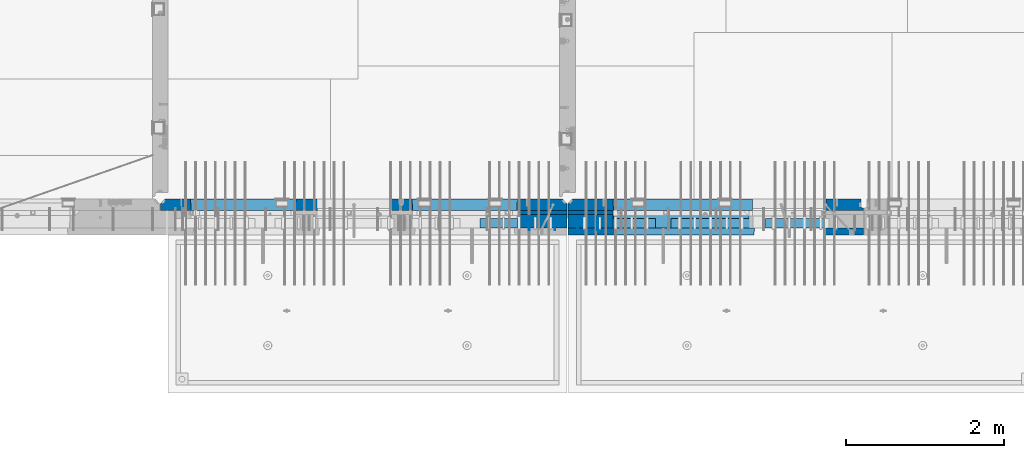
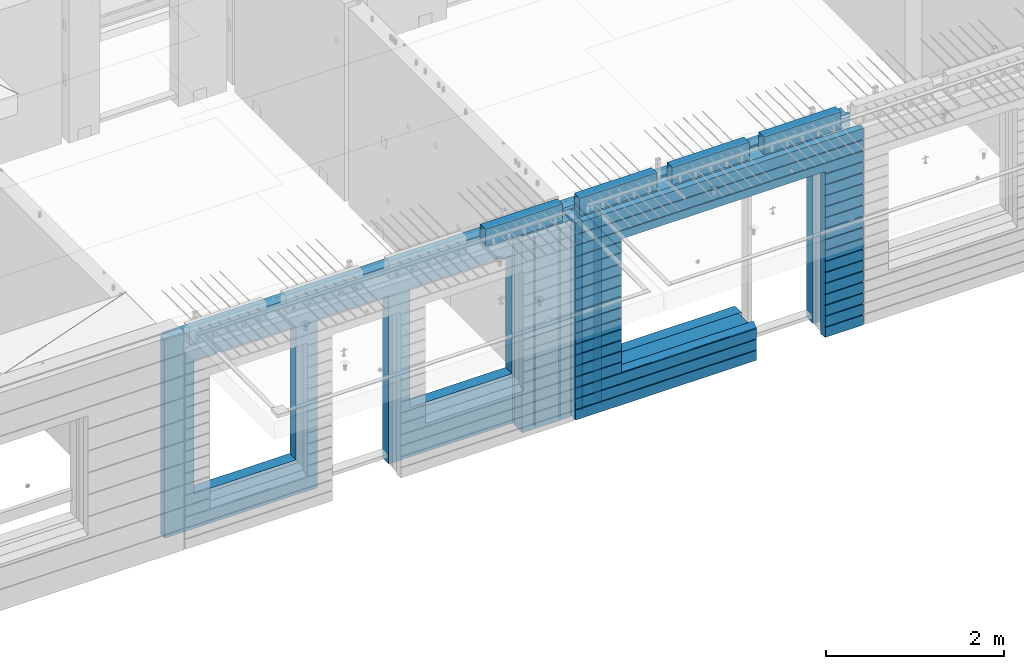
# One storey, part 231 of 349: 16 walls, 8 elements without a shape of their own.
"""IFC2X3 building model written with IfcOpenShell, lengths in millimetres."""

from ifc_helpers import new_model, si_unit, frame, origin_with_axes, place, context, subcontext, project, spatial, faceted_brep, material, type_object, element, aggregate, save


model = new_model("IFC2X3")

# Units and contexts
model_context = context("Model", 3, precision=1e-05, world=origin_with_axes())
body_context = subcontext(model_context, "Body", "Model", "MODEL_VIEW")
ifc_project = project(units=[si_unit("LENGTHUNIT", "METRE", prefix="MILLI"), si_unit("AREAUNIT", "SQUARE_METRE"), si_unit("VOLUMEUNIT", "CUBIC_METRE"), si_unit("MASSUNIT", "GRAM", prefix="KILO"), si_unit("TIMEUNIT", "SECOND"), si_unit("PLANEANGLEUNIT", "RADIAN"), si_unit("SOLIDANGLEUNIT", "STERADIAN"), si_unit("THERMODYNAMICTEMPERATUREUNIT", "DEGREE_CELSIUS"), si_unit("LUMINOUSINTENSITYUNIT", "LUMEN")], contexts=[model_context])

# Site, building, storey
site_placement = place(None, origin_with_axes())
site = spatial("IfcSite", under=ifc_project, at=site_placement, CompositionType="ELEMENT")
building_placement = place(site_placement, origin_with_axes())
building = spatial("IfcBuilding", under=site, at=building_placement, CompositionType="ELEMENT")
storey_placement = place(building_placement, origin_with_axes())
storey = spatial("IfcBuildingStorey", under=building, at=storey_placement, Name="4", CompositionType="ELEMENT", Elevation=0.0)

# Assembly, walls
assembly_1_placement = place(storey_placement, origin_with_axes())
assembly_1 = element("IfcElementAssembly", 1, at=assembly_1_placement, inside=storey, AssemblyPlace="NOTDEFINED", PredefinedType="REINFORCEMENT_UNIT")
ifc_material_1 = material(Name="Undefined")
wall_type_1 = type_object("IfcWallType", PredefinedType="NOTDEFINED")
wall_1_placement = place(assembly_1_placement, frame((21325.0, 7780.0, 92115.0), z_axis=(0.0, 0.0, 1.0), x_axis=(0.0, -1.0, 0.0)))
wall_1 = element("IfcWall", 2, at=wall_1_placement, type_object=wall_type_1, material=ifc_material_1, Name="(PD)", context=body_context, shape_type="Brep", body=[
    faceted_brep([(0.0, 5.0, -1300.0), (0.0, 5.0, 1300.0), (180.0, 5.0, 1300.0), (180.0, 5.0, -1300.0), (0.0, -5.0, 1300.0), (180.0, -5.0, 1300.0), (0.0, -5.0, -1300.0), (180.0, -5.0, -1300.0)], [[[0, 1, 2, 3]], [[1, 4, 5, 2]], [[4, 6, 7, 5]], [[6, 0, 3, 7]], [[5, 7, 3, 2]], [[6, 4, 1, 0]]]),
])
wall_2_placement = place(assembly_1_placement, frame((21650.0, 7780.0, 92115.0), z_axis=(0.0, 0.0, 1.0), x_axis=(0.0, -1.0, 0.0)))
wall_2 = element("IfcWall", 3, at=wall_2_placement, type_object=wall_type_1, material=ifc_material_1, Name="(PD)", context=body_context, shape_type="Brep", body=[
    faceted_brep([(0.0, 5.0, -1300.0), (0.0, 5.0, 1300.0), (180.0, 5.0, 1300.0), (180.0, 5.0, -1300.0), (0.0, -5.0, 1300.0), (180.0, -5.0, 1300.0), (0.0, -5.0, -1300.0), (180.0, -5.0, -1300.0)], [[[0, 1, 2, 3]], [[1, 4, 5, 2]], [[4, 6, 7, 5]], [[6, 0, 3, 7]], [[5, 7, 3, 2]], [[6, 4, 1, 0]]]),
])

assembly_2_placement = place(storey_placement, origin_with_axes())
assembly_2 = element("IfcElementAssembly", 4, at=assembly_2_placement, inside=storey, AssemblyPlace="NOTDEFINED", PredefinedType="REINFORCEMENT_UNIT")
wall_3_placement = place(assembly_2_placement, frame((22190.0, 7780.0, 92115.0), z_axis=(0.0, 0.0, 1.0), x_axis=(0.0, -1.0, 0.0)))
wall_3 = element("IfcWall", 5, at=wall_3_placement, type_object=wall_type_1, material=ifc_material_1, Name="(PD)", context=body_context, shape_type="Brep", body=[
    faceted_brep([(0.0, 5.0, -1300.0), (0.0, 5.0, 1300.0), (180.0, 5.0, 1300.0), (180.0, 5.0, -1300.0), (0.0, -5.0, 1300.0), (180.0, -5.0, 1300.0), (0.0, -5.0, -1300.0), (180.0, -5.0, -1300.0)], [[[0, 1, 2, 3]], [[1, 4, 5, 2]], [[4, 6, 7, 5]], [[6, 0, 3, 7]], [[5, 7, 3, 2]], [[6, 4, 1, 0]]]),
])
wall_4_placement = place(assembly_2_placement, frame((21940.0, 7780.0, 92115.0), z_axis=(0.0, 0.0, 1.0), x_axis=(0.0, -1.0, 0.0)))
wall_4 = element("IfcWall", 6, at=wall_4_placement, type_object=wall_type_1, material=ifc_material_1, Name="(PD)", context=body_context, shape_type="Brep", body=[
    faceted_brep([(0.0, 5.0, -1300.0), (0.0, 5.0, 1300.0), (180.0, 5.0, 1300.0), (180.0, 5.0, -1300.0), (0.0, -5.0, 1300.0), (180.0, -5.0, 1300.0), (0.0, -5.0, -1300.0), (180.0, -5.0, -1300.0)], [[[0, 1, 2, 3]], [[1, 4, 5, 2]], [[4, 6, 7, 5]], [[6, 0, 3, 7]], [[5, 7, 3, 2]], [[6, 4, 1, 0]]]),
])

# Assemblies, wall
assembly_3_placement = place(storey_placement, origin_with_axes())
assembly_3 = element("IfcElementAssembly", 7, at=assembly_3_placement, inside=storey, AssemblyPlace="NOTDEFINED", PredefinedType="REINFORCEMENT_UNIT")
assembly_4_placement = place(assembly_3_placement, origin_with_axes())
assembly_4 = element("IfcElementAssembly", 8, at=assembly_4_placement, Name="Steel Assembly", AssemblyPlace="NOTDEFINED", PredefinedType="NOTDEFINED")
aggregate(assembly_3, [assembly_4])
ifc_material_2 = material()
wall_type_2 = type_object("IfcWallType", PredefinedType="NOTDEFINED")
wall_5_placement = place(assembly_4_placement, frame((20699.9998568133, 7690.00021946163, 93590.0), z_axis=(0.0, 0.0, 1.0), x_axis=(1.0, 0.0, 0.0)))
wall_5 = element("IfcWall", 9, at=wall_5_placement, type_object=wall_type_2, material=ifc_material_2, context=body_context, shape_type="Brep", body=[
    faceted_brep([(0.0, 60.0, -120.0), (0.0, 60.0, 120.0), (1000.0, 60.0, 120.0), (1000.0, 60.0, -120.0), (0.0, -60.0, 120.0), (1000.0, -60.0, 120.0), (0.0, -60.0, -120.0), (1000.0, -60.0, -120.0)], [[[0, 1, 2, 3]], [[1, 4, 5, 2]], [[4, 6, 7, 5]], [[6, 0, 3, 7]], [[5, 7, 3, 2]], [[6, 4, 1, 0]]]),
])
aggregate(assembly_4, [wall_5])

# Assemblies, walls
assembly_5_placement = place(storey_placement, origin_with_axes())
assembly_5 = element("IfcElementAssembly", 10, at=assembly_5_placement, inside=storey, AssemblyPlace="NOTDEFINED", PredefinedType="REINFORCEMENT_UNIT")
assembly_6_placement = place(assembly_5_placement, origin_with_axes())
assembly_6 = element("IfcElementAssembly", 11, at=assembly_6_placement, Name="Steel Assembly", AssemblyPlace="NOTDEFINED", PredefinedType="NOTDEFINED")
wall_6_placement = place(assembly_6_placement, frame((24309.9998568133, 7690.00021946163, 93590.0), z_axis=(0.0, 0.0, 1.0), x_axis=(1.0, 0.0, 0.0)))
wall_6 = element("IfcWall", 12, at=wall_6_placement, type_object=wall_type_2, material=ifc_material_2, context=body_context, shape_type="Brep", body=[
    faceted_brep([(0.0, 60.0, -120.0), (0.0, 60.0, 120.0), (1000.0, 60.0, 120.0), (1000.0, 60.0, -120.0), (0.0, -60.0, 120.0), (1000.0, -60.0, 120.0), (0.0, -60.0, -120.0), (1000.0, -60.0, -120.0)], [[[0, 1, 2, 3]], [[1, 4, 5, 2]], [[4, 6, 7, 5]], [[6, 0, 3, 7]], [[5, 7, 3, 2]], [[6, 4, 1, 0]]]),
])
aggregate(assembly_6, [wall_6])
assembly_7_placement = place(assembly_5_placement, origin_with_axes())
assembly_7 = element("IfcElementAssembly", 13, at=assembly_7_placement, Name="Steel Assembly", AssemblyPlace="NOTDEFINED", PredefinedType="NOTDEFINED")
wall_7_placement = place(assembly_7_placement, frame((23119.9998568133, 7690.00021946163, 93590.0), z_axis=(0.0, 0.0, 1.0), x_axis=(1.0, 0.0, 0.0)))
wall_7 = element("IfcWall", 14, at=wall_7_placement, type_object=wall_type_2, material=ifc_material_2, context=body_context, shape_type="Brep", body=[
    faceted_brep([(0.0, 60.0, -120.0), (0.0, 60.0, 120.0), (1000.0, 60.0, 120.0), (1000.0, 60.0, -120.0), (0.0, -60.0, 120.0), (1000.0, -60.0, 120.0), (0.0, -60.0, -120.0), (1000.0, -60.0, -120.0)], [[[0, 1, 2, 3]], [[1, 4, 5, 2]], [[4, 6, 7, 5]], [[6, 0, 3, 7]], [[5, 7, 3, 2]], [[6, 4, 1, 0]]]),
])
aggregate(assembly_7, [wall_7])
assembly_8_placement = place(assembly_5_placement, origin_with_axes())
assembly_8 = element("IfcElementAssembly", 15, at=assembly_8_placement, Name="Steel Assembly", AssemblyPlace="NOTDEFINED", PredefinedType="NOTDEFINED")
aggregate(assembly_5, [assembly_8, assembly_7, assembly_6])
wall_8_placement = place(assembly_8_placement, frame((21919.9998568133, 7690.00021946163, 93590.0), z_axis=(0.0, 0.0, 1.0), x_axis=(1.0, 0.0, 0.0)))
wall_8 = element("IfcWall", 16, at=wall_8_placement, type_object=wall_type_2, material=ifc_material_2, context=body_context, shape_type="Brep", body=[
    faceted_brep([(0.0, 60.0, -120.0), (0.0, 60.0, 120.0), (1000.0, 60.0, 120.0), (1000.0, 60.0, -120.0), (0.0, -60.0, 120.0), (1000.0, -60.0, 120.0), (0.0, -60.0, -120.0), (1000.0, -60.0, -120.0)], [[[0, 1, 2, 3]], [[1, 4, 5, 2]], [[4, 6, 7, 5]], [[6, 0, 3, 7]], [[5, 7, 3, 2]], [[6, 4, 1, 0]]]),
])
aggregate(assembly_8, [wall_8])

# Wall
ifc_material_3 = material(Name="CONCRETE/C35/45")
wall_type_3 = type_object("IfcWallType", PredefinedType="NOTDEFINED")
wall_9_placement = place(assembly_1_placement, frame((21810.0, 7925.0, 92112.5), z_axis=(0.0, 0.0, 1.0), x_axis=(-1.0, 3.00000001838171e-08, 0.0)))
wall_9 = element("IfcWall", 17, at=wall_9_placement, type_object=wall_type_3, material=ifc_material_3, context=body_context, shape_type="Brep", body=[
    faceted_brep([(5145.0, 75.0, -1357.5), (5145.0, -15.0, -1357.5), (5085.0, -75.0, -1357.5), (3165.00051719707, -75.0, -1357.5), (3161.15436335092, 75.0, -1357.5), (5085.0, -75.0, 1357.5), (5145.0, -15.0, 1357.5), (5145.0, 75.0, 1357.5), (10.0, 75.0, 1357.5), (10.0, -15.0, 1357.5), (70.0, -75.0, 1357.5), (10.0, -15.0, -1357.5), (70.0, -75.0, -1357.5), (10.0, 75.0, -1357.5), (2238.84667104322, 75.0, -1357.5), (2235.00051719707, -75.0, -1357.5), (2238.84667104322, 75.0, 948.653846153844), (2235.00051719707, -75.0, 952.5), (635.00013572734, -75.0, -682.5), (639.054189781393, 75.0, -678.445945945947), (639.054189781393, 75.0, 948.445945945947), (635.00013572734, -75.0, 952.5), (1965.00013572734, -75.0, -682.5), (1960.94608167329, 75.0, -678.445945945947), (1965.00013572734, -75.0, 952.5), (1960.94608167329, 75.0, 948.445945945947), (4764.99937278789, -75.0, -882.5), (4760.94531873383, 75.0, -878.445945945947), (3439.05342684194, 75.0, -878.445945945947), (3434.99937278789, -75.0, -882.5), (3165.00051719707, -75.0, 952.5), (3434.99937278789, -75.0, 952.5), (4764.99937278789, -75.0, 952.5), (4760.94531873383, 75.0, 948.445945945947), (3439.05342684194, 75.0, 948.445945945947), (3161.15436335092, 75.0, 948.653846153844)], [[[0, 1, 2, 3, 4]], [[5, 2, 1, 6]], [[0, 7, 6, 1]], [[5, 6, 7, 8, 9, 10]], [[9, 11, 12, 10]], [[8, 13, 11, 9]], [[12, 11, 13, 14, 15]], [[15, 14, 16, 17]], [[18, 19, 20, 21]], [[22, 23, 19, 18]], [[23, 22, 24, 25]], [[21, 20, 25, 24]], [[26, 27, 28, 29]], [[3, 2, 5, 10, 12, 15, 17, 30], [26, 29, 31, 32], [22, 18, 21, 24]], [[27, 26, 32, 33]], [[31, 34, 33, 32]], [[29, 28, 34, 31]], [[13, 8, 7, 0, 4, 35, 16, 14], [27, 33, 34, 28], [23, 25, 20, 19]], [[17, 16, 35, 30]], [[4, 3, 30, 35]]]),
])

wall_10_placement = place(assembly_2_placement, frame((25550.0, 7925.0, 92112.5), z_axis=(0.0, 0.0, 1.0), x_axis=(-1.0, 3.00000001838171e-08, 0.0)))
wall_10 = element("IfcWall", 18, at=wall_10_placement, type_object=wall_type_3, material=ifc_material_3, context=body_context, shape_type="Brep", body=[
    faceted_brep([(0.0, 75.0, 1357.5), (0.0, 75.0, -1357.5), (0.0, 45.0, -1357.5), (0.0, 45.0, 1357.5), (475.000517197066, -75.0, -1357.5), (478.846671043222, 75.0, -1357.5), (478.846671043219, 75.0, 948.653846153844), (475.000517197066, -75.0, 952.5), (32.5, -75.0, -1357.5), (32.5, 32.0, -1357.5), (32.5, -75.0, 1357.5), (32.5, 32.0, 1357.5), (3675.0, -75.0, 1357.5), (3735.0, -15.0, 1357.5), (3735.0, 75.0, 1357.5), (3735.0, 75.0, -1357.5), (3735.0, -15.0, -1357.5), (3675.0, -75.0, -1357.5), (1405.00051719707, -75.0, -1357.5), (1401.15436335091, 75.0, -1357.5), (1405.00051719707, -75.0, -882.5), (1401.15436335091, 75.0, -878.445945945947), (1334.05403802673, 75.0, 948.653846153844), (3160.9460816706, 75.0, -878.445945945947), (3160.9460816706, 75.0, 948.445945945947), (1401.15436335091, 75.0, 948.653846153844), (1330.00013572465, -75.0, 952.5), (1405.00051719707, -75.0, 952.5), (3165.00013572465, -75.0, -882.5), (3165.00013572465, -75.0, 952.5)], [[[0, 1, 2, 3]], [[4, 5, 6, 7]], [[8, 9, 2, 1, 5, 4]], [[10, 11, 9, 8]], [[3, 2, 9, 11]], [[10, 12, 13, 14, 0, 3, 11]], [[15, 14, 13, 16]], [[12, 17, 16, 13]], [[15, 16, 17, 18, 19]], [[19, 18, 20, 21]], [[22, 6, 5, 1, 0, 14, 15, 19, 21, 23, 24, 25]], [[26, 7, 6, 22, 25, 27]], [[28, 20, 18, 17, 12, 10, 8, 4, 7, 26, 27, 29]], [[25, 24, 29, 27]], [[23, 28, 29, 24]], [[21, 20, 28, 23]]]),
])

wall_type_4 = type_object("IfcWallType", PredefinedType="NOTDEFINED")
wall_11_placement = place(assembly_1_placement, frame((21800.0000381475, 7825.0, 92112.5), z_axis=(0.0, 0.0, 1.0), x_axis=(-1.0, 3.00000001838171e-08, 0.0)))
wall_11 = element("IfcWall", 19, at=wall_11_placement, type_object=wall_type_4, material=ifc_material_3, context=body_context, shape_type="Brep", body=[
    faceted_brep([(0.0, 25.0, -1357.5), (0.0, 25.0, 1357.5), (625.001908754726, 25.0, 1357.5), (625.001908754726, 25.0, -1357.5), (0.0, -25.0, 1357.5), (625.001908754726, -25.0, 1357.5), (0.0, -25.0, -1357.5), (625.001908754726, -25.0, -1357.5)], [[[0, 1, 2, 3]], [[1, 4, 5, 2]], [[4, 6, 7, 5]], [[6, 0, 3, 7]], [[5, 7, 3, 2]], [[6, 4, 1, 0]]]),
])

wall_12_placement = place(assembly_2_placement, frame((22385.0000381475, 7825.00011629906, 92112.5), z_axis=(0.0, 0.0, 1.0), x_axis=(-1.0, 3.00000001838171e-08, 0.0)))
wall_12 = element("IfcWall", 20, at=wall_12_placement, type_object=wall_type_4, material=ifc_material_3, context=body_context, shape_type="Brep", body=[
    faceted_brep([(0.0, 25.0, -1357.5), (0.0, 25.0, 1357.5), (570.001908754726, 25.0, 1357.5), (570.001908754726, 25.0, -1357.5), (0.0, -25.0, 1357.5), (570.001908754726, -25.0, 1357.5), (0.0, -25.0, -1357.5), (570.001908754726, -25.0, -1357.5)], [[[0, 1, 2, 3]], [[1, 4, 5, 2]], [[4, 6, 7, 5]], [[6, 0, 3, 7]], [[5, 7, 3, 2]], [[6, 4, 1, 0]]]),
])

ifc_material_4 = material(Name="SPU")
wall_type_5 = type_object("IfcWallType", PredefinedType="NOTDEFINED")
wall_13_placement = place(assembly_1_placement, frame((21800.0000381475, 7715.0, 92102.5), z_axis=(0.0, 0.0, 1.0), x_axis=(-1.0, 3.00000001838171e-08, 0.0)))
wall_13 = element("IfcWall", 21, at=wall_13_placement, type_object=wall_type_5, material=ifc_material_4, context=body_context, shape_type="Brep", body=[
    faceted_brep([(0.0, 85.0, -1347.5), (0.0, 85.0, 1347.5), (625.001908754726, 85.0, 1347.5), (625.001908754726, 85.0, -1347.5), (0.0, -85.0, 1347.5), (625.001908754726, -85.0, 1347.5), (0.0, -85.0, -1347.5), (625.001908754726, -85.0, -1347.5)], [[[0, 1, 2, 3]], [[1, 4, 5, 2]], [[4, 6, 7, 5]], [[6, 0, 3, 7]], [[5, 7, 3, 2]], [[6, 4, 1, 0]]]),
])

aggregate(assembly_1, [wall_13, wall_11, wall_1, wall_2, wall_9])

wall_14_placement = place(assembly_2_placement, frame((22385.0000381475, 7715.00011629906, 92102.5), z_axis=(0.0, 0.0, 1.0), x_axis=(-1.0, 3.00000001838171e-08, 0.0)))
wall_14 = element("IfcWall", 22, at=wall_14_placement, type_object=wall_type_5, material=ifc_material_4, context=body_context, shape_type="Brep", body=[
    faceted_brep([(0.0, 85.0, -1347.5), (0.0, 85.0, 1347.5), (570.001908754726, 85.0, 1347.5), (570.001908754726, 85.0, -1347.5), (0.0, -85.0, 1347.5), (570.001908754726, -85.0, 1347.5), (0.0, -85.0, -1347.5), (570.001908754726, -85.0, -1347.5)], [[[0, 1, 2, 3]], [[1, 4, 5, 2]], [[4, 6, 7, 5]], [[6, 0, 3, 7]], [[5, 7, 3, 2]], [[6, 4, 1, 0]]]),
])

ifc_material_5 = material(Name="CONCRETE/C30/37")
wall_type_6 = type_object("IfcWallType", PredefinedType="NOTDEFINED")
wall_15_placement = place(assembly_2_placement, frame((25550.0, 7587.5, 92102.5), z_axis=(0.0, 0.0, 1.0), x_axis=(-1.0, 3.00000001838171e-08, 0.0)))
wall_15 = element("IfcWall", 23, at=wall_15_placement, type_object=wall_type_6, material=ifc_material_5, context=body_context, shape_type="Brep", body=[
    faceted_brep([(3135.00013572465, 42.5, -912.000000055254), (3135.00013572465, 42.5, -912.5), (3134.8486205936, 41.2121213860491, -911.742424344731), (3735.0, 32.4999991126861, -1049.99999959956), (3735.0, 32.4999992506973, -1060.00000000076), (1383.82179161871, 32.4999992506973, -1060.00000000076), (1383.82179160247, 32.4999991126861, -1049.99999959956), (3735.0, 42.5, -1062.00000005522), (1384.99845837354, 42.5, -1062.00000005522), (3735.0, 42.5, -1198.00000011075), (1384.99845837354, 42.5, -1198.00000011075), (3735.0, 32.4999991121604, -1199.99999959957), (1383.8217916024, 32.4999991121604, -1199.99999959957), (3735.0, 32.4999992501671, -1210.00000000079), (1383.82179161864, 32.4999992501671, -1210.00000000079), (3735.0, 42.5, -1212.00000005524), (1384.99845837354, 42.5, -1212.00000005524), (3735.0, 42.5, -1347.5), (1384.99845837354, 42.5, -1347.5), (3735.0, -42.5, -1347.5), (1374.99679170687, -42.5, -1347.5), (3.63797880709171e-12, 32.4999992499725, 1039.99999999921), (3735.0, 32.4999992499725, 1039.99999999921), (3735.0, 42.5, 1037.99999994476), (0.0, 42.5, 1037.99999994476), (3.63797880709171e-12, 32.4999991119639, 1050.00000040043), (3735.0, 32.4999991119639, 1050.00000040043), (0.0, 42.5, 1051.99999988925), (3735.0, 42.5, 1051.99999988925), (0.0, 42.5, 1187.99999994476), (3735.0, 42.5, 1187.99999994476), (-3.63797880709171e-12, 32.499999249967, 1189.99999999923), (3735.0, 32.499999249967, 1189.99999999923), (-3.63797880709171e-12, 32.4999991119576, 1200.00000040043), (3735.0, 32.4999991119576, 1200.00000040043), (0.0, 42.5, 1201.99999988925), (3735.0, 42.5, 1201.99999988925), (0.0, 42.5, 1347.5), (3735.0, 42.5, 1347.5), (0.0, -42.5, 1347.5), (3735.0, -42.5, 1347.5), (3125.00013572465, -42.5, 927.5), (3125.00013572465, -42.5, -862.5), (1374.99679170687, -42.5, -862.5), (0.0, -42.5, -1347.5), (505.000125040202, -42.5, -1347.5), (505.000125040206, -42.5, 927.5), (505.000125040206, -42.5, 932.502857142856), (1370.00013572465, -42.5, 932.502857142856), (1374.99679170687, -42.5, 932.5), (3125.00013572465, -42.5, 932.5), (0.0, 42.5, -1347.5), (494.998458373539, 42.5, -1347.5), (0.0, 42.5, -1212.00000005524), (494.998458373539, 42.5, -1212.00000005524), (0.0, 32.4999992501671, -1210.00000000079), (496.175125128437, 32.4999992501671, -1210.00000000079), (0.0, 32.4999991121604, -1199.99999959957), (496.175125144673, 32.4999991121604, -1199.99999959957), (0.0, 42.5, -1198.00000011075), (494.998458373539, 42.5, -1198.00000011075), (0.0, 42.5, -1062.00000005522), (494.998458373539, 42.5, -1062.00000005522), (0.0, 32.4999992506973, -1060.00000000076), (496.175125128375, 32.4999992506973, -1060.00000000076), (0.0, 32.4999991126861, -1049.99999959956), (496.175125144611, 32.4999991126861, -1049.99999959956), (0.0, 42.5, -1048.00000011074), (494.998458373539, 42.5, -1048.00000011074), (0.0, 42.5, -912.000000055254), (494.998458373539, 42.5, -912.000000055254), (0.0, 32.4999992512376, -910.000000000786), (496.175125128309, 32.4999992512376, -910.000000000786), (0.0, 32.499999113239, -899.99999959959), (496.175125144546, 32.499999113239, -899.99999959959), (0.0, 42.5, -898.000000110769), (494.998458373539, 42.5, -898.000000110769), (0.0, 42.5, -762.000000055225), (494.998458373539, 42.5, -762.000000055225), (0.0, 32.4999992517696, -760.000000000757), (496.175125128244, 32.4999992517696, -760.000000000757), (0.0, 32.4999991137702, -749.99999959956), (496.175125144484, 32.4999991137702, -749.99999959956), (0.0, 42.5, -748.00000011074), (494.998458373539, 42.5, -748.00000011074), (0.0, 42.5, -612.000000055239), (494.998458373539, 42.5, -612.000000055239), (0.0, 32.4999992522971, -610.000000000771), (496.175125128182, 32.4999992522971, -610.000000000771), (0.0, 32.4999991143004, -599.99999959956), (496.175125144422, 32.4999991143004, -599.99999959956), (0.0, 42.5, -598.000000110755), (494.998458373539, 42.5, -598.000000110755), (0.0, 42.5, -462.000000055239), (494.998458373539, 42.5, -462.000000055239), (0.0, 32.4999992528365, -460.000000000771), (496.17512512812, 32.4999992528365, -460.000000000771), (0.0, 32.4999991148252, -449.999999599575), (496.17512514436, 32.4999991148252, -449.999999599575), (0.0, 42.5, -448.000000110755), (494.998458373539, 42.5, -448.000000110755), (0.0, 42.5, -312.000000055254), (494.998458373539, 42.5, -312.000000055254), (0.0, 32.4999992533649, -310.000000000786), (496.175125128058, 32.4999992533649, -310.000000000786), (0.0, 32.4999991153618, -299.99999959959), (496.175125144298, 32.4999991153618, -299.99999959959), (0.0, 42.5, -298.000000110769), (494.998458373539, 42.5, -298.000000110769), (0.0, 42.5, -162.000000055239), (494.998458373539, 42.5, -162.000000055239), (0.0, 32.4999992538978, -160.000000000757), (496.175125127997, 32.4999992538978, -160.000000000757), (0.0, 32.4999991158993, -149.99999959956), (496.175125144237, 32.4999991158993, -149.99999959956), (0.0, 42.5, -148.000000110755), (494.998458373539, 42.5, -148.000000110755), (0.0, 42.5, -12.0000000552391), (494.998458373539, 42.5, -12.0000000552391), (0.0, 32.4999992538942, -10.0000000007858), (496.175125127997, 32.4999992538942, -10.0000000007858), (3.63797880709171e-12, 32.4999992499852, 889.999999999229), (3.63797880709171e-12, 32.4999991119857, 900.000000400425), (496.175125144691, 32.4999991119857, 900.000000400425), (496.175125128459, 32.4999992499852, 889.999999999229), (0.0, 42.5, 887.999999944761), (494.998458373539, 42.5, 887.999999944761), (0.0, 42.5, 751.999999889245), (494.998458373539, 42.5, 751.999999889245), (0.0, 32.4999991120039, 750.00000040044), (496.175125144691, 32.4999991120039, 750.00000040044), (0.0, 32.4999992499997, 739.999999999229), (496.175125128455, 32.4999992499997, 739.999999999229), (0.0, 42.5, 737.999999944761), (494.998458373539, 42.5, 737.999999944761), (0.0, 42.5, 601.99999988926), (494.998458373539, 42.5, 601.99999988926), (0.0, 32.4999991120094, 600.00000040044), (496.175125144691, 32.4999991120094, 600.00000040044), (0.0, 32.499999250017, 589.999999999229), (496.175125128455, 32.499999250017, 589.999999999229), (0.0, 42.5, 587.999999944775), (494.998458373539, 42.5, 587.999999944775), (0.0, 42.5, 451.999999889231), (494.998458373539, 42.5, 451.999999889231), (0.0, 32.4999991120258, 450.000000400411), (496.175125144688, 32.4999991120258, 450.000000400411), (0.0, 32.4999992500289, 439.999999999214), (496.175125128451, 32.4999992500289, 439.999999999214), (0.0, 42.5, 437.999999944746), (494.998458373539, 42.5, 437.999999944746), (0.0, 42.5, 301.999999889245), (494.998458373539, 42.5, 301.999999889245), (-3.63797880709171e-12, 32.4999991120458, 300.00000040044), (496.175125144688, 32.4999991120458, 300.00000040044), (-3.63797880709171e-12, 32.4999992500416, 289.999999999229), (496.175125128451, 32.4999992500416, 289.999999999229), (0.0, 42.5, 287.999999944761), (494.998458373539, 42.5, 287.999999944761), (0.0, 42.5, 151.99999988926), (494.998458373539, 42.5, 151.99999988926), (0.0, 32.4999991120549, 150.00000040044), (496.175125144684, 32.4999991120549, 150.00000040044), (0.0, 32.4999992500552, 139.999999999229), (496.175125128448, 32.4999992500552, 139.999999999229), (0.0, 42.5, 137.999999944775), (494.998458373539, 42.5, 137.999999944775), (0.0, 42.5, 1.99999988924537), (494.998458373539, 42.5, 1.99999988924537), (0.0, 32.4999991158911, 4.00425051338971e-07), (496.175125144237, 32.4999991158911, 4.00425051338971e-07), (0.0, 42.5, 901.999999889245), (494.998458373539, 42.5, 901.999999889245), (494.998458373539, 42.5, 927.5), (505.000517197066, 42.5, 927.5), (1360.00013572465, 42.5, 927.5), (1370.00013572465, 42.5, 927.5), (1375.00051719707, 42.5, 927.5), (1384.99845837354, 42.5, 927.5), (3125.00013572465, 42.5, 927.5), (3135.00013572465, 42.5, 927.5), (3735.0, 42.5, 901.999999889245), (3135.00013572465, 42.5, 901.999999889245), (3735.0, 32.4999991119857, 900.000000400425), (3133.82366503195, 32.4999991119857, 900.000000400425), (3735.0, 32.4999992499852, 889.999999999229), (3133.82366504818, 32.4999992499852, 889.999999999229), (3735.0, 42.5, 887.999999944761), (3135.00013572465, 42.5, 887.999999944761), (3735.0, 42.5, 751.999999889245), (3135.00013572465, 42.5, 751.999999889245), (3735.0, 32.4999991120039, 750.00000040044), (3133.82366503195, 32.4999991120039, 750.00000040044), (3735.0, 32.4999992499997, 739.999999999229), (3133.82366504818, 32.4999992499997, 739.999999999229), (3735.0, 42.5, 737.999999944761), (3135.00013572465, 42.5, 737.999999944761), (3735.0, 42.5, 601.99999988926), (3135.00013572465, 42.5, 601.99999988926), (3735.0, 32.4999991120094, 600.00000040044), (3133.82366503195, 32.4999991120094, 600.00000040044), (3735.0, 32.499999250017, 589.999999999229), (3133.82366504818, 32.499999250017, 589.999999999229), (3735.0, 42.5, 587.999999944775), (3135.00013572465, 42.5, 587.999999944775), (3735.0, 42.5, 451.999999889231), (3135.00013572465, 42.5, 451.999999889231), (3735.0, 32.4999991120258, 450.000000400411), (3133.82366503195, 32.4999991120258, 450.000000400411), (3735.0, 32.4999992500289, 439.999999999214), (3133.82366504818, 32.4999992500289, 439.999999999214), (3735.0, 42.5, 437.999999944746), (3135.00013572465, 42.5, 437.999999944746), (3735.0, 42.5, 301.999999889245), (3135.00013572465, 42.5, 301.999999889245), (3735.0, 32.4999991120458, 300.00000040044), (3133.82366503195, 32.4999991120458, 300.00000040044), (3735.0, 32.4999992500416, 289.999999999229), (3133.82366504819, 32.4999992500416, 289.999999999229), (3735.0, 42.5, 287.999999944761), (3135.00013572465, 42.5, 287.999999944761), (3735.0, 42.5, 151.99999988926), (3135.00013572465, 42.5, 151.99999988926), (3735.0, 32.4999991120549, 150.00000040044), (3133.82366503195, 32.4999991120549, 150.00000040044), (3735.0, 32.4999992500552, 139.999999999229), (3133.82366504819, 32.4999992500552, 139.999999999229), (3735.0, 42.5, 137.999999944775), (3135.00013572465, 42.5, 137.999999944775), (3735.0, 42.5, 1.99999988924537), (3135.00013572465, 42.5, 1.99999988924537), (3735.0, 32.4999991158911, 4.00425051338971e-07), (3735.0, 32.4999992538942, -10.0000000007858), (3133.82366504864, 32.4999992538942, -10.0000000007858), (3133.8236650324, 32.4999991158911, 4.00425051338971e-07), (3735.0, 42.5, -12.0000000552391), (3135.00013572465, 42.5, -12.0000000552391), (3735.0, 42.5, -148.000000110755), (3135.00013572465, 42.5, -148.000000110755), (3735.0, 32.4999991158993, -149.99999959956), (3133.8236650324, 32.4999991158993, -149.99999959956), (3735.0, 32.4999992538978, -160.000000000757), (3133.82366504864, 32.4999992538978, -160.000000000757), (3735.0, 42.5, -162.000000055239), (3135.00013572465, 42.5, -162.000000055239), (3735.0, 42.5, -298.000000110769), (3135.00013572465, 42.5, -298.000000110769), (3735.0, 32.4999991153618, -299.99999959959), (3133.82366503234, 32.4999991153618, -299.99999959959), (3735.0, 32.4999992533649, -310.000000000786), (3133.82366504858, 32.4999992533649, -310.000000000786), (3735.0, 42.5, -312.000000055254), (3135.00013572465, 42.5, -312.000000055254), (3735.0, 42.5, -448.000000110755), (3135.00013572465, 42.5, -448.000000110755), (3735.0, 32.4999991148252, -449.999999599575), (3133.82366503228, 32.4999991148252, -449.999999599575), (3735.0, 32.4999992528365, -460.000000000771), (3133.82366504852, 32.4999992528365, -460.000000000771), (3735.0, 42.5, -462.000000055239), (3135.00013572465, 42.5, -462.000000055239), (3735.0, 42.5, -598.000000110755), (3135.00013572465, 42.5, -598.000000110755), (3735.0, 32.4999991143004, -599.99999959956), (3133.82366503222, 32.4999991143004, -599.99999959956), (3735.0, 32.4999992522971, -610.000000000771), (3133.82366504845, 32.4999992522971, -610.000000000771), (3735.0, 42.5, -612.000000055239), (3135.00013572465, 42.5, -612.000000055239), (3735.0, 42.5, -748.00000011074), (3135.00013572465, 42.5, -748.00000011074), (3735.0, 32.4999991137702, -749.99999959956), (3133.82366503216, 32.4999991137702, -749.99999959956), (3735.0, 32.4999992517696, -760.000000000757), (3133.82366504839, 32.4999992517696, -760.000000000757), (3735.0, 42.5, -762.000000055225), (3135.00013572465, 42.5, -762.000000055225), (3735.0, 42.5, -898.000000110769), (3135.00013572465, 42.5, -898.000000110769), (3735.0, 32.499999113239, -899.99999959959), (3133.82366503209, 32.499999113239, -899.99999959959), (3133.82366504284, 32.4999992045623, -906.617646590923), (3735.0, 42.5, -1048.00000011074), (3735.0, 42.5, -912.000000055254), (3735.0, 32.4999992512376, -910.000000000786), (1384.99845837354, 42.5, -1048.00000011074), (1384.99845837354, 42.5, -912.5), (1384.84691798997, 41.2121213860719, -911.742424344746), (1383.82179161877, 32.4999992512376, -910.000000000786), (1383.82179161327, 32.4999992045614, -906.617646590908)], [[[0, 1, 2]], [[3, 4, 5, 6]], [[4, 7, 8, 5]], [[7, 9, 10, 8]], [[9, 11, 12, 10]], [[11, 13, 14, 12]], [[13, 15, 16, 14]], [[15, 17, 18, 16]], [[17, 19, 20, 18]], [[21, 22, 23, 24]], [[25, 26, 22, 21]], [[27, 28, 26, 25]], [[28, 27, 29, 30]], [[31, 32, 30, 29]], [[33, 34, 32, 31]], [[35, 36, 34, 33]], [[37, 38, 36, 35]], [[37, 39, 40, 38]], [[41, 42, 43, 20, 19, 40, 39, 44, 45, 46, 47, 48, 49, 50]], [[44, 51, 52, 45]], [[51, 53, 54, 52]], [[53, 55, 56, 54]], [[55, 57, 58, 56]], [[57, 59, 60, 58]], [[59, 61, 62, 60]], [[61, 63, 64, 62]], [[63, 65, 66, 64]], [[65, 67, 68, 66]], [[67, 69, 70, 68]], [[69, 71, 72, 70]], [[71, 73, 74, 72]], [[73, 75, 76, 74]], [[75, 77, 78, 76]], [[77, 79, 80, 78]], [[79, 81, 82, 80]], [[81, 83, 84, 82]], [[83, 85, 86, 84]], [[85, 87, 88, 86]], [[87, 89, 90, 88]], [[89, 91, 92, 90]], [[91, 93, 94, 92]], [[93, 95, 96, 94]], [[95, 97, 98, 96]], [[97, 99, 100, 98]], [[99, 101, 102, 100]], [[101, 103, 104, 102]], [[103, 105, 106, 104]], [[105, 107, 108, 106]], [[107, 109, 110, 108]], [[109, 111, 112, 110]], [[111, 113, 114, 112]], [[113, 115, 116, 114]], [[115, 117, 118, 116]], [[117, 119, 120, 118]], [[121, 122, 123, 124]], [[125, 121, 124, 126]], [[127, 125, 126, 128]], [[129, 127, 128, 130]], [[131, 129, 130, 132]], [[133, 131, 132, 134]], [[135, 133, 134, 136]], [[137, 135, 136, 138]], [[139, 137, 138, 140]], [[141, 139, 140, 142]], [[143, 141, 142, 144]], [[145, 143, 144, 146]], [[147, 145, 146, 148]], [[149, 147, 148, 150]], [[151, 149, 150, 152]], [[153, 151, 152, 154]], [[155, 153, 154, 156]], [[157, 155, 156, 158]], [[159, 157, 158, 160]], [[161, 159, 160, 162]], [[163, 161, 162, 164]], [[165, 163, 164, 166]], [[167, 165, 166, 168]], [[169, 167, 168, 170]], [[119, 169, 170, 120]], [[117, 115, 113, 111, 109, 107, 105, 103, 101, 99, 97, 95, 93, 91, 89, 87, 85, 83, 81, 79, 77, 75, 73, 71, 69, 67, 65, 63, 61, 59, 57, 55, 53, 51, 44, 39, 37, 35, 33, 31, 29, 27, 25, 21, 24, 171, 122, 121, 125, 127, 129, 131, 133, 135, 137, 139, 141, 143, 145, 147, 149, 151, 153, 155, 157, 159, 161, 163, 165, 167, 169, 119]], [[122, 171, 172, 123]], [[173, 47, 46, 45, 52, 54, 56, 58, 60, 62, 64, 66, 68, 70, 72, 74, 76, 78, 80, 82, 84, 86, 88, 90, 92, 94, 96, 98, 100, 102, 104, 106, 108, 110, 112, 114, 116, 118, 120, 170, 168, 166, 164, 162, 160, 158, 156, 154, 152, 150, 148, 146, 144, 142, 140, 138, 136, 134, 132, 130, 128, 126, 124, 123, 172]], [[174, 175, 176, 177, 178, 49, 48, 47, 173]], [[49, 178, 179, 180, 50]], [[178, 177, 176, 175, 174, 173, 172, 171, 24, 23, 181, 182, 180, 179]], [[181, 183, 184, 182]], [[183, 185, 186, 184]], [[185, 187, 188, 186]], [[187, 189, 190, 188]], [[189, 191, 192, 190]], [[191, 193, 194, 192]], [[193, 195, 196, 194]], [[195, 197, 198, 196]], [[197, 199, 200, 198]], [[199, 201, 202, 200]], [[201, 203, 204, 202]], [[203, 205, 206, 204]], [[205, 207, 208, 206]], [[207, 209, 210, 208]], [[209, 211, 212, 210]], [[211, 213, 214, 212]], [[213, 215, 216, 214]], [[215, 217, 218, 216]], [[217, 219, 220, 218]], [[219, 221, 222, 220]], [[221, 223, 224, 222]], [[223, 225, 226, 224]], [[225, 227, 228, 226]], [[227, 229, 230, 228]], [[231, 232, 233, 234]], [[232, 235, 236, 233]], [[235, 237, 238, 236]], [[237, 239, 240, 238]], [[239, 241, 242, 240]], [[241, 243, 244, 242]], [[243, 245, 246, 244]], [[245, 247, 248, 246]], [[247, 249, 250, 248]], [[249, 251, 252, 250]], [[251, 253, 254, 252]], [[253, 255, 256, 254]], [[255, 257, 258, 256]], [[257, 259, 260, 258]], [[259, 261, 262, 260]], [[261, 263, 264, 262]], [[263, 265, 266, 264]], [[265, 267, 268, 266]], [[267, 269, 270, 268]], [[269, 271, 272, 270]], [[271, 273, 274, 272]], [[273, 275, 276, 274]], [[275, 277, 278, 276]], [[277, 279, 280, 278]], [[41, 50, 180, 182, 184, 186, 188, 190, 192, 194, 196, 198, 200, 202, 204, 206, 208, 210, 212, 214, 216, 218, 220, 222, 224, 226, 228, 230, 234, 233, 236, 238, 240, 242, 244, 246, 248, 250, 252, 254, 256, 258, 260, 262, 264, 266, 268, 270, 272, 274, 276, 278, 280, 281, 42]], [[229, 231, 234, 230]], [[227, 225, 223, 221, 219, 217, 215, 213, 211, 209, 207, 205, 203, 201, 199, 197, 195, 193, 191, 189, 187, 185, 183, 181, 23, 22, 26, 28, 30, 32, 34, 36, 38, 40, 19, 17, 15, 13, 11, 9, 7, 4, 3, 282, 283, 284, 279, 277, 275, 273, 271, 269, 267, 265, 263, 261, 259, 257, 255, 253, 251, 249, 247, 245, 243, 241, 239, 237, 235, 232, 231, 229]], [[0, 283, 282, 285, 286, 1]], [[287, 2, 1, 286]], [[288, 284, 283, 0, 2, 287]], [[280, 279, 284, 288, 289, 281]], [[43, 42, 281, 289]], [[288, 287, 286, 285, 6, 5, 8, 10, 12, 14, 16, 18, 20, 43, 289]], [[282, 3, 6, 285]]]),
])

ifc_material_6 = material(Name="COS5gt")
wall_type_7 = type_object("IfcWallType", PredefinedType="NOTDEFINED")
wall_16_placement = place(assembly_2_placement, frame((25075.0, 7740.0, 92102.5), z_axis=(0.0, 0.0, 1.0), x_axis=(-1.0, 3.00000001838171e-08, 0.0)))
wall_16 = element("IfcWall", 24, at=wall_16_placement, type_object=wall_type_7, material=ifc_material_6, context=body_context, shape_type="Brep", body=[
    faceted_brep([(2690.0, 90.0, -1297.5), (2690.0, 90.0, -1347.5), (970.000517197066, 90.0, -1347.5), (970.000517197066, 90.0, -1297.5), (2690.0, 110.0, -1297.5), (970.000517197066, 110.0, -1297.5), (2690.0, 110.0, 1347.5), (2690.0, -110.0, 1347.5), (2690.0, -110.0, -1347.5), (0.0, 110.0, 1347.5), (0.0, -110.0, 1347.5), (0.0, 110.0, 1002.5), (0.0, -110.0, 1002.5), (970.000517197066, 110.0, 1002.5), (970.000517197066, -110.0, 1002.5), (970.000517197066, 110.0, 952.5), (970.000517197066, -110.0, 958.445945945947), (2685.9460816706, -110.000000000001, -868.445945945947), (970.000517197066, -110.0, -868.445945945947), (970.000517197066, -110.0, -1347.5), (2685.9460816706, -110.0, 958.445945945947), (2680.00013572465, 110.0, -857.5), (2680.00013572465, 110.0, -862.5), (2680.00013572465, 110.0, 952.5), (970.000517197066, 110.0, -862.5), (2650.00013572465, 110.0, -862.5)], [[[0, 1, 2, 3]], [[4, 0, 3, 5]], [[6, 7, 8, 1, 0, 4]], [[9, 10, 7, 6]], [[10, 9, 11, 12]], [[12, 11, 13, 14]], [[14, 13, 15, 16]], [[17, 18, 19, 8, 7, 10, 12, 14, 16, 20]], [[21, 22, 17, 20, 23]], [[16, 15, 23, 20]], [[13, 11, 9, 6, 4, 5, 24, 25, 22, 21, 23, 15]], [[18, 17, 22, 25, 24]], [[5, 3, 2, 19, 18, 24]], [[1, 8, 19, 2]]]),
])

aggregate(assembly_2, [wall_14, wall_12, wall_3, wall_4, wall_15, wall_16, wall_10])

save(model, "model.ifc")
